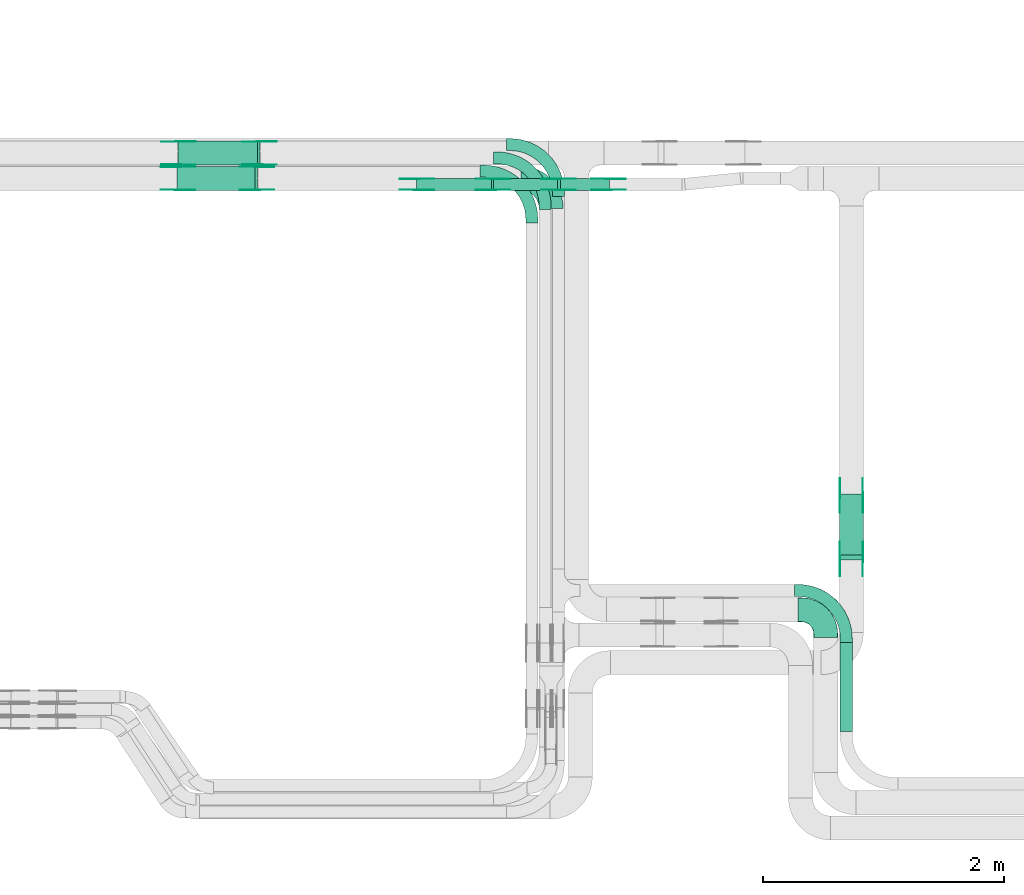
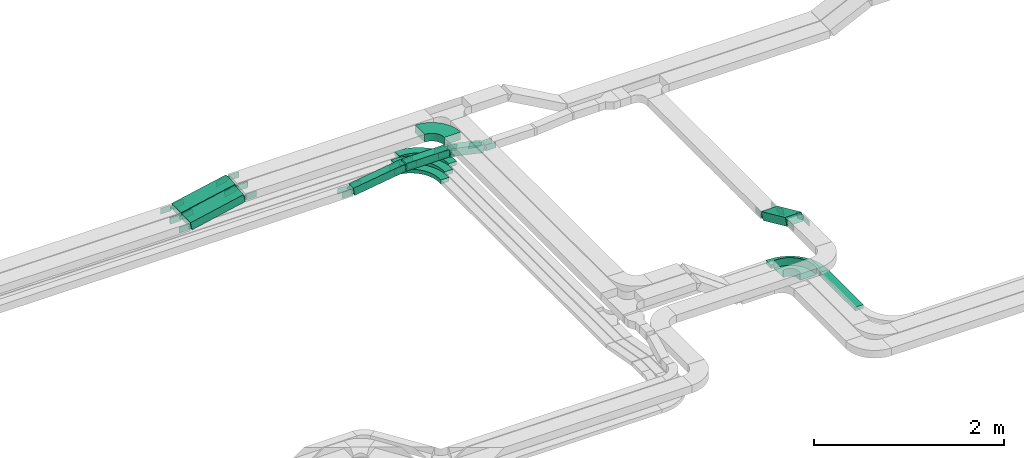
# One storey, part 12 of 25: 46 flow fittings, 7 flow segments.
"""IFC2X3 building model written with IfcOpenShell, lengths in millimetres."""

import ifcopenshell
import ifcopenshell.guid

model = None  # the IFC model being written
_history = None  # IfcOwnerHistory: only IFC2X3 demands one
_inside = {}  # id of a spatial element -> (the spatial element, [elements in it])
_under = {}  # id of a project, library or spatial element -> (it, [spatial elements below it])
_declared = {}  # id of a project -> (the project, [libraries it declares])
_typed = {}  # id of a type object -> (the type object, [elements of that type])
_made_of = {}  # id of a material, layer set ... -> (it, [elements and type objects made of it])


def new_model(schema):
    """Start an empty IFC model of exactly this schema.

    Asked for "IFC4X3", IfcOpenShell would pick the latest addendum, in which some entities
    have other attributes; the version numbers below select the first issue.
    IFC2X3 requires an IfcOwnerHistory on every rooted entity: one is made here for all.
    """
    global model, _history
    if schema == "IFC4X3":
        model = ifcopenshell.file(schema_version=(4, 3, 0, 0))
    else:
        model = ifcopenshell.file(schema=schema)
    _inside.clear()
    _under.clear()
    _declared.clear()
    _typed.clear()
    _made_of.clear()
    _history = None
    if model.schema == "IFC2X3":
        org = make("IfcOrganization", Name="unknown")
        user = make(
            "IfcPersonAndOrganization",
            ThePerson=make("IfcPerson", FamilyName="unknown"),
            TheOrganization=org,
        )
        app = make(
            "IfcApplication",
            ApplicationDeveloper=org,
            Version="unknown",
            ApplicationFullName="unknown",
            ApplicationIdentifier="unknown",
        )
        _history = make(
            "IfcOwnerHistory",
            OwningUser=user,
            OwningApplication=app,
            ChangeAction="ADDED",
            CreationDate=0,
        )
    return model


def make(cls, **values):
    """One entity of the class cls with the attributes given. An attribute that is None is left unset."""
    return model.create_entity(
        cls, **{name: value for name, value in values.items() if value is not None}
    )


def entity(cls, *values):
    """Any entity or typed value of the class cls, its attributes in the order of the schema. None: left unset."""
    e = model.create_entity(cls)
    for i, value in enumerate(values):
        if value is not None:
            e[i] = value
    return e


def rooted(cls, **values):
    """An entity with a GlobalId (a new one), such as an element, a storey or a relation."""
    return make(cls, GlobalId=ifcopenshell.guid.new(), OwnerHistory=_history, **values)


def si_unit(unit_type, name, prefix=None):
    """IfcSIUnit, for example si_unit("LENGTHUNIT", "METRE", prefix="MILLI")."""
    return make("IfcSIUnit", UnitType=unit_type, Prefix=prefix, Name=name)


def converted_unit(unit_type, name, factor, base, dimensions=None, offset=None):
    """IfcConversionBasedUnit, such as the inch: factor (a typed value) times the base unit."""
    return make(
        "IfcConversionBasedUnit"
        if offset is None
        else "IfcConversionBasedUnitWithOffset",
        ConversionOffset=offset,
        Dimensions=None
        if dimensions is None
        else entity("IfcDimensionalExponents", *dimensions),
        UnitType=unit_type,
        Name=name,
        ConversionFactor=make(
            "IfcMeasureWithUnit", ValueComponent=factor, UnitComponent=base
        ),
    )


def derived_unit(unit_type, elements):
    """IfcDerivedUnit: a product of units, each with its exponent."""
    return make(
        "IfcDerivedUnit",
        Elements=[
            make("IfcDerivedUnitElement", Unit=unit, Exponent=power)
            for unit, power in elements
        ],
        UnitType=unit_type,
    )


def assignment(units):
    """IfcUnitAssignment: the units of a project."""
    return None if units is None else make("IfcUnitAssignment", Units=units)


def point(xyz):
    """IfcCartesianPoint."""
    return None if xyz is None else make("IfcCartesianPoint", Coordinates=xyz)


def direction(xyz):
    """IfcDirection."""
    return None if xyz is None else make("IfcDirection", DirectionRatios=xyz)


def frame(location, z_axis=None, x_axis=None):
    """IfcAxis2Placement3D, a coordinate frame: its origin and axes. An axis left out is left unset."""
    return make(
        "IfcAxis2Placement3D",
        Location=point(location),
        Axis=direction(z_axis),
        RefDirection=direction(x_axis),
    )


def frame_2d(location, x_axis=None):
    """IfcAxis2Placement2D, a coordinate frame in the plane: its origin and x axis."""
    return make(
        "IfcAxis2Placement2D", Location=point(location), RefDirection=direction(x_axis)
    )


def origin():
    """The frame at (0, 0, 0) with its axes left unset."""
    return frame((0.0, 0.0, 0.0))


def origin_2d_with_axis():
    """The frame at (0, 0) in the plane with the x axis (1, 0) written out."""
    return frame_2d((0.0, 0.0), x_axis=(1.0, 0.0))


def place(relative_to, where):
    """IfcLocalPlacement: puts the frame where relative to a parent placement (None: the world)."""
    return make(
        "IfcLocalPlacement", PlacementRelTo=relative_to, RelativePlacement=where
    )


def context(
    kind, dimensions, precision=None, world=None, true_north=None, identifier=None
):
    """IfcGeometricRepresentationContext, for example the 3D "Model" context."""
    return make(
        "IfcGeometricRepresentationContext",
        ContextIdentifier=identifier,
        ContextType=kind,
        CoordinateSpaceDimension=dimensions,
        Precision=precision,
        WorldCoordinateSystem=world,
        TrueNorth=true_north,
    )


def subcontext(parent, identifier, kind, view, scale=None):
    """IfcGeometricRepresentationSubContext, for example "Body" below "Model"."""
    return make(
        "IfcGeometricRepresentationSubContext",
        ContextIdentifier=identifier,
        ContextType=kind,
        ParentContext=parent,
        TargetScale=scale,
        TargetView=view,
    )


def project(units=None, contexts=None):
    """IfcProject with its units and contexts."""
    return rooted(
        "IfcProject",
        Name="project",
        RepresentationContexts=contexts,
        UnitsInContext=assignment(units),
    )


def spatial(cls, under=None, at=None, **own):
    """A site, building, storey or space (cls), placed at a placement, below another one or the project."""
    s = rooted(cls, ObjectPlacement=at, **own)
    if under is not None:
        _under.setdefault(under.id(), (under, []))[1].append(s)
    return s


def polyline(points):
    """IfcPolyline through the points."""
    return make("IfcPolyline", Points=[point(p) for p in points])


def circle_curve(where, radius):
    """IfcCircle in the frame where."""
    return make("IfcCircle", Position=where, Radius=radius)


def parameter(value):
    """IfcParameterValue: where a trimmed curve begins or ends, as a parameter of its basis curve."""
    return model.create_entity("IfcParameterValue", value)


def trimmed(basis, trim1, trim2, sense, master):
    """IfcTrimmedCurve: the piece of a basis curve between two trims."""
    return make(
        "IfcTrimmedCurve",
        BasisCurve=basis,
        Trim1=trim1,
        Trim2=trim2,
        SenseAgreement=sense,
        MasterRepresentation=master,
    )


def segment(curve, same_sense, transition):
    """IfcCompositeCurveSegment."""
    return make(
        "IfcCompositeCurveSegment",
        Transition=transition,
        SameSense=same_sense,
        ParentCurve=curve,
    )


def composite_curve(segments, self_intersect=None):
    """IfcCompositeCurve: segments joined end to end."""
    return make("IfcCompositeCurve", Segments=segments, SelfIntersect=self_intersect)


def profile(cls, at=None, kind="AREA", **sizes):
    """A parametric profile (cls). Its sizes go by their IFC names, for example OverallWidth=200.0."""
    return make(cls, ProfileType=kind, Position=at, **sizes)


def rectangle(**sizes):
    """IfcRectangleProfileDef."""
    return profile("IfcRectangleProfileDef", **sizes)


def outline(outer, holes=None, kind="AREA"):
    """IfcArbitraryClosedProfileDef: a profile drawn as a closed curve; with holes, ...WithVoids."""
    if holes is None:
        return make("IfcArbitraryClosedProfileDef", ProfileType=kind, OuterCurve=outer)
    return make(
        "IfcArbitraryProfileDefWithVoids",
        ProfileType=kind,
        OuterCurve=outer,
        InnerCurves=holes,
    )


def extrude(swept, where, along, depth):
    """IfcExtrudedAreaSolid: the profile swept, set in the frame where, extruded along a direction by depth."""
    return make(
        "IfcExtrudedAreaSolid",
        SweptArea=swept,
        Position=where,
        ExtrudedDirection=direction(along),
        Depth=depth,
    )


def faces_of(points, faces, orient=None, outer=None):
    """IfcFace entities. A face is a list of loops; a loop is a list of indices into points, from 0.

    orient and outer hold one flag for each loop. By default every Orientation is true, the
    first loop of a face is its IfcFaceOuterBound and the others are IfcFaceBound.
    """
    made = []
    for i, loops in enumerate(faces):
        bounds = []
        for j, loop in enumerate(loops):
            is_outer = j == 0 if outer is None else outer[i][j]
            bounds.append(
                make(
                    "IfcFaceOuterBound" if is_outer else "IfcFaceBound",
                    Bound=make("IfcPolyLoop", Polygon=[points[k] for k in loop]),
                    Orientation=True if orient is None else orient[i][j],
                )
            )
        made.append(make("IfcFace", Bounds=bounds))
    return made


def faceted_brep(points, faces, orient=None, outer=None, voids=None):
    """IfcFacetedBrep: a solid bounded by flat faces; with voids (closed shells), ...WithVoids."""
    shared = [point(p) for p in points]
    hull = make("IfcClosedShell", CfsFaces=faces_of(shared, faces, orient, outer))
    if voids is None:
        return make("IfcFacetedBrep", Outer=hull)
    return make(
        "IfcFacetedBrepWithVoids",
        Outer=hull,
        Voids=[
            make(cls, CfsFaces=faces_of(shared, fs, o, b)) for cls, fs, o, b in voids
        ],
    )


def shape(context_of_items, identifier, shape_type, items):
    """IfcShapeRepresentation: the items that make up one representation, for example the "Body"."""
    return make(
        "IfcShapeRepresentation",
        ContextOfItems=context_of_items,
        RepresentationIdentifier=identifier,
        RepresentationType=shape_type,
        Items=items,
    )


def source(mapping_origin, context_of_items, identifier, shape_type, items):
    """IfcRepresentationMap: a shape defined once, which mapped items show again and again."""
    return make(
        "IfcRepresentationMap",
        MappingOrigin=mapping_origin,
        MappedRepresentation=shape(context_of_items, identifier, shape_type, items),
    )


def transform(
    local_origin,
    x_axis=None,
    y_axis=None,
    z_axis=None,
    scale=None,
    scale2=None,
    scale3=None,
    uniform=True,
):
    """IfcCartesianTransformationOperator3D, or its non-uniform kind. x_axis, y_axis, z_axis: its Axis1, 2, 3."""
    if uniform:
        return make(
            "IfcCartesianTransformationOperator3D",
            Axis1=direction(x_axis),
            Axis2=direction(y_axis),
            LocalOrigin=point(local_origin),
            Scale=scale,
            Axis3=direction(z_axis),
        )
    return make(
        "IfcCartesianTransformationOperator3DnonUniform",
        Axis1=direction(x_axis),
        Axis2=direction(y_axis),
        LocalOrigin=point(local_origin),
        Scale=scale,
        Axis3=direction(z_axis),
        Scale2=scale2,
        Scale3=scale3,
    )


def mapped(mapping_source, mapping_target):
    """IfcMappedItem: shows the shape of a source again, moved by a transform."""
    return make(
        "IfcMappedItem", MappingSource=mapping_source, MappingTarget=mapping_target
    )


def material(Name=None, Category=None):
    """IfcMaterial."""
    return make("IfcMaterial", Name=Name, Category=Category)


def made_of(thing, what):
    """Note that an element or type object is made of a material, layer set ...; save() writes the relation."""
    if what is not None:
        _made_of.setdefault(what.id(), (what, []))[1].append(thing)
    return thing


def type_object(cls, material=None, **own):
    """A type object (cls), such as IfcWallType, which elements share."""
    return made_of(rooted(cls, **own), material)


def type_shapes(of_type, sources):
    """Give a type object the sources (RepresentationMaps) that its elements show as mapped items."""
    of_type.RepresentationMaps = sources


def element(
    cls,
    number,
    at=None,
    inside=None,
    cuts=None,
    type_object=None,
    material=None,
    context=None,
    identifier="Body",
    shape_type=None,
    held_by="IfcProductDefinitionShape",
    body=None,
    shapes=None,
    **own,
):
    """One element of the class cls, such as IfcWall. Its Tag is "e" and its number.

    at: its placement. inside: the storey or other place that contains it. cuts: it is an
    opening in that element (IfcRelVoidsElement). A single representation is given by context,
    identifier, shape_type and body (its items); several are given by shapes. held_by: the class
    of the entity that holds the representations. save() writes the other relations.
    """
    e = rooted(cls, Tag="e%d" % number, ObjectPlacement=at, **own)
    if body is not None:
        shapes = [shape(context, identifier, shape_type, body)]
    if shapes is not None:
        e.Representation = make(held_by, Representations=shapes)
    if inside is not None:
        _inside.setdefault(inside.id(), (inside, []))[1].append(e)
    if cuts is not None:
        rooted(
            "IfcRelVoidsElement", RelatingBuildingElement=cuts, RelatedOpeningElement=e
        )
    if type_object is not None:
        _typed.setdefault(type_object.id(), (type_object, []))[1].append(e)
    return made_of(e, material)


def aggregate(whole, parts):
    """IfcRelAggregates: a whole, such as a stair, and the parts it consists of."""
    return rooted("IfcRelAggregates", RelatingObject=whole, RelatedObjects=parts)


def save(model, path):
    """Write the relations noted so far, then the file.

    IfcRelAggregates (storeys below a building ...), IfcRelContainedInSpatialStructure (elements
    in a storey), IfcRelDefinesByType, IfcRelAssociatesMaterial and IfcRelDeclares: one each for
    every whole, place, type object, material and project.
    """
    for whole, parts in _under.values():
        aggregate(whole, parts)
    for where, things in _inside.values():
        rooted(
            "IfcRelContainedInSpatialStructure",
            RelatedElements=things,
            RelatingStructure=where,
        )
    for kind, things in _typed.values():
        rooted("IfcRelDefinesByType", RelatedObjects=things, RelatingType=kind)
    for what, things in _made_of.values():
        rooted("IfcRelAssociatesMaterial", RelatedObjects=things, RelatingMaterial=what)
    for by, libraries in _declared.values():
        rooted("IfcRelDeclares", RelatingContext=by, RelatedDefinitions=libraries)
    model.write(path)


model = new_model("IFC2X3")

# Units and contexts
model_context = context("Model", 3, precision=0.01, world=origin(), true_north=direction((6.12303176911189e-17, 1.0)))
body_context = subcontext(model_context, "Body", "Model", "MODEL_VIEW")
ifc_project = project(units=[si_unit("LENGTHUNIT", "METRE", prefix="MILLI"), si_unit("AREAUNIT", "SQUARE_METRE"), si_unit("VOLUMEUNIT", "CUBIC_METRE"), converted_unit("PLANEANGLEUNIT", "DEGREE", entity("IfcRatioMeasure", 0.0174532925199433), si_unit("PLANEANGLEUNIT", "RADIAN"), dimensions=[0, 0, 0, 0, 0, 0, 0]), si_unit("MASSUNIT", "GRAM", prefix="KILO"), derived_unit("MASSDENSITYUNIT", [(si_unit("MASSUNIT", "GRAM", prefix="KILO"), 1), (si_unit("LENGTHUNIT", "METRE"), -3)]), derived_unit("MOMENTOFINERTIAUNIT", [(si_unit("LENGTHUNIT", "METRE"), 4)]), si_unit("TIMEUNIT", "SECOND"), si_unit("FREQUENCYUNIT", "HERTZ"), si_unit("THERMODYNAMICTEMPERATUREUNIT", "DEGREE_CELSIUS"), derived_unit("THERMALTRANSMITTANCEUNIT", [(si_unit("MASSUNIT", "GRAM", prefix="KILO"), 1), (si_unit("THERMODYNAMICTEMPERATUREUNIT", "KELVIN"), -1), (si_unit("TIMEUNIT", "SECOND"), -3)]), derived_unit("VOLUMETRICFLOWRATEUNIT", [(si_unit("LENGTHUNIT", "METRE"), 3), (si_unit("TIMEUNIT", "SECOND"), -1)]), derived_unit("MASSFLOWRATEUNIT", [(si_unit("MASSUNIT", "GRAM", prefix="KILO"), 1), (si_unit("TIMEUNIT", "SECOND"), -1)]), derived_unit("ROTATIONALFREQUENCYUNIT", [(si_unit("TIMEUNIT", "SECOND"), -1)]), si_unit("ELECTRICCURRENTUNIT", "AMPERE"), si_unit("ELECTRICVOLTAGEUNIT", "VOLT"), si_unit("POWERUNIT", "WATT"), si_unit("FORCEUNIT", "NEWTON", prefix="KILO"), si_unit("ILLUMINANCEUNIT", "LUX"), si_unit("LUMINOUSFLUXUNIT", "LUMEN"), si_unit("LUMINOUSINTENSITYUNIT", "CANDELA"), derived_unit("USERDEFINED", [(si_unit("MASSUNIT", "GRAM", prefix="KILO"), -1), (si_unit("LENGTHUNIT", "METRE"), -2), (si_unit("TIMEUNIT", "SECOND"), 3), (si_unit("LUMINOUSFLUXUNIT", "LUMEN"), 1)]), derived_unit("LINEARVELOCITYUNIT", [(si_unit("LENGTHUNIT", "METRE"), 1), (si_unit("TIMEUNIT", "SECOND"), -1)]), si_unit("PRESSUREUNIT", "PASCAL"), derived_unit("USERDEFINED", [(si_unit("LENGTHUNIT", "METRE"), -2), (si_unit("MASSUNIT", "GRAM", prefix="KILO"), 1), (si_unit("TIMEUNIT", "SECOND"), -2)]), derived_unit("LINEARFORCEUNIT", [(si_unit("MASSUNIT", "GRAM", prefix="KILO"), 1), (si_unit("LENGTHUNIT", "METRE"), 1), (si_unit("TIMEUNIT", "SECOND"), -2), (si_unit("LENGTHUNIT", "METRE"), -1)]), derived_unit("PLANARFORCEUNIT", [(si_unit("MASSUNIT", "GRAM", prefix="KILO"), 1), (si_unit("LENGTHUNIT", "METRE"), 1), (si_unit("TIMEUNIT", "SECOND"), -2), (si_unit("LENGTHUNIT", "METRE"), -2)])], contexts=[model_context])

# Site, building, storey
site_placement = place(None, frame((0.0, -0.00077364408347762, 0.0)))
site = spatial("IfcSite", under=ifc_project, at=site_placement, CompositionType="ELEMENT")
building_placement = place(site_placement, origin())
building = spatial("IfcBuilding", under=site, at=building_placement, CompositionType="ELEMENT")
storey_placement = place(building_placement, frame((0.0, 0.0, 24000.0)))
storey = spatial("IfcBuildingStorey", under=building, at=storey_placement, CompositionType="ELEMENT", Elevation=24000.0)

# Flow segments
cable_carrier_segment_type = type_object("IfcCableCarrierSegmentType", PredefinedType="CABLETRAYSEGMENT")
flow_segment_1_placement = place(storey_placement, frame((35443.0827924389, 9874.94253623869, 2660.0)))
element("IfcFlowSegment", 1, at=flow_segment_1_placement, inside=storey, type_object=cable_carrier_segment_type, context=body_context, shape_type="SweptSolid", body=[
    extrude(rectangle(XDim=741.957859858951, YDim=100.000000000003, at=origin_2d_with_axis()), frame((50.0, 370.978929929476, 0.0), z_axis=(0.0, 0.0, 1.0), x_axis=(0.0, -1.0, 0.0)), (0.0, 0.0, 1.0), 49.9999999999973),
])
flow_segment_2_placement = place(storey_placement, frame((29938.2616836239, 14367.8235638228, 2902.46442439066)))
element("IfcFlowSegment", 2, at=flow_segment_2_placement, inside=storey, type_object=cable_carrier_segment_type, context=body_context, shape_type="SweptSolid", body=[
    extrude(rectangle(XDim=100.000000000002, YDim=199.999999999998, at=frame_2d((0.0, 0.0), x_axis=(0.0, 1.0))), frame((10.3606064094728, 100.0, 48.9148017968845), z_axis=(0.978296035937588, 0.0, 0.207212128189452), x_axis=(0.0, 1.0, 0.0)), (0.0, 0.0, 1.0), 662.323913296523),
])
flow_segment_3_placement = place(storey_placement, frame((29945.3217316781, 14577.8235638228, 2902.37682935703)))
element("IfcFlowSegment", 3, at=flow_segment_3_placement, inside=storey, type_object=cable_carrier_segment_type, context=body_context, shape_type="SweptSolid", body=[
    extrude(rectangle(XDim=99.9999999999976, YDim=199.999999999998, at=frame_2d((0.0, 0.0), x_axis=(0.0, 1.0))), frame((10.1686392190644, 100.0, 48.955068955446), z_axis=(0.979101379108944, 0.0, 0.203372784381206), x_axis=(0.0, 1.0, 0.0)), (0.0, 0.0, 1.0), 675.292929646166),
])
flow_segment_4_placement = place(storey_placement, frame((32566.6569789908, 14367.8235638228, 2743.47367481726)))
element("IfcFlowSegment", 4, at=flow_segment_4_placement, inside=storey, type_object=cable_carrier_segment_type, context=body_context, shape_type="SweptSolid", body=[
    extrude(rectangle(XDim=528.117388360168, YDim=99.9999999999989, at=frame_2d((-2.1600499167107e-12, 1.08357767203415e-12), x_axis=(1.0, 0.0))), frame((264.058694180091, 50.0, 0.0)), (0.0, 0.0, 1.0), 100.000000000003),
])
flow_segment_5_placement = place(storey_placement, frame((31923.8620126346, 14367.8235638228, 2651.25271057159)))
element("IfcFlowSegment", 5, at=flow_segment_5_placement, inside=storey, type_object=cable_carrier_segment_type, context=body_context, shape_type="SweptSolid", body=[
    extrude(rectangle(XDim=99.9999999999993, YDim=99.9999999999989, at=frame_2d((0.0, 2.16715534406831e-12), x_axis=(1.0, 0.0))), frame((7.27643817058358, 50.0, 49.4677010538147), z_axis=(0.9893540210763, 0.0, 0.145528763411759), x_axis=(-0.145528763411759, 0.0, 0.9893540210763)), (0.0, 0.0, 1.0), 632.403171778338),
])
flow_segment_6_placement = place(storey_placement, frame((33097.6188980036, 14367.8235638228, 2652.69744610507)))
element("IfcFlowSegment", 6, at=flow_segment_6_placement, inside=storey, type_object=cable_carrier_segment_type, context=body_context, shape_type="SweptSolid", body=[
    extrude(rectangle(XDim=99.9999999999984, YDim=99.9999999999989, at=frame_2d((0.0, 4.68958205601666e-13), x_axis=(0.0, 1.0))), frame((10.8547522753288, 50.0, 139.271259078084), z_axis=(0.976150470581497, 0.0, -0.217095045506624), x_axis=(0.0, 1.0, 0.0)), (0.0, 0.0, 1.0), 416.70105984177),
])
flow_segment_7_placement = place(storey_placement, frame((35435.6156945545, 11298.7278543462, 2659.6732728103)))
element("IfcFlowSegment", 7, at=flow_segment_7_placement, inside=storey, type_object=cable_carrier_segment_type, context=body_context, shape_type="SweptSolid", body=[
    extrude(rectangle(XDim=100.000000000003, YDim=556.494140571385, at=frame_2d((8.5265128291212e-14, 2.41939801526314e-12), x_axis=(0.0, 1.0))), frame((0.0, 274.095709476673, 160.326727189748), z_axis=(1.0, 0.0, 0.0), x_axis=(0.0, -0.910954180221993, 0.412507553307909)), (0.0, 0.0, 1.0), 199.999999999998),
])

# Flow fittings
ifc_material_1 = material(Name="G")
cable_carrier_fitting_type_1 = type_object("IfcCableCarrierFittingType", PredefinedType="NOTDEFINED", material=ifc_material_1)
shared_shape_1 = source(origin(), body_context, "Body", "SweptSolid", [
    extrude(outline(composite_curve([segment(trimmed(circle_curve(frame_2d((-41.4651162790697, 0.0), x_axis=(1.0, 0.0)), 25.0), [parameter(90.0000000000007)], [parameter(270.0)], True, "PARAMETER"), True, "CONTINUOUS"), segment(polyline([(-41.4651162790697, -25.0), (-29.9651162790697, -25.0)]), True, "CONTINUOUS"), segment(polyline([(-29.9651162790697, -25.0), (-28.1046511627907, -38.5)]), True, "CONTINUOUS"), segment(polyline([(-28.1046511627907, -38.5), (99.5348837209303, -38.5)]), True, "CONTINUOUS"), segment(polyline([(99.5348837209303, -38.5), (99.5348837209303, 38.5)]), True, "CONTINUOUS"), segment(polyline([(99.5348837209303, 38.5), (-28.1046511627907, 38.5)]), True, "CONTINUOUS"), segment(polyline([(-28.1046511627907, 38.5), (-29.9651162790697, 25.0)]), True, "CONTINUOUS"), segment(polyline([(-29.9651162790697, 25.0), (-41.46511627907, 25.0)]), True, "CONTINUOUS")], self_intersect=False)), frame((41.4651162790697, 0.0, 0.0), z_axis=(0.0, 0.0, -1.0), x_axis=(1.0, 0.0, 0.0)), (0.0, 0.0, -1.0), 2.0),
])
type_shapes(cable_carrier_fitting_type_1, [shared_shape_1])
for number, where, z_axis, x_axis in (
    (8, (29942.1106465126, 14372.3635638126, 2950.0), (0.0, -1.0, 0.0), (0.978296035937579, 0.0, 0.207212128189496)),
    (9, (30603.0827924388, 14372.3635638126, 3090.0), (0.0, -1.0, 0.0), (-0.978296035937579, 0.0, -0.207212128189496)),
    (10, (29949.0781880745, 14582.3635638127, 2950.0), (0.0, -1.0, 0.0), (0.979101379108938, 0.0, 0.203372784381233)),
    (11, (32561.706674952, 14372.3635638126, 2793.47367481727), (0.0, -1.0, 0.0), (-0.989354021076303, 0.0, -0.145528763411741)),
    (12, (31926.2408475988, 14372.3635638126, 2700.0), (0.0, -1.0, 0.0), (0.989354021076303, 0.0, 0.145528763411741)),
    (13, (33101.706674952, 14463.2835638329, 2793.47367481728), (0.0, 1.0, 0.0), (0.976150470581499, 0.0, -0.217095045506614)),
    (14, (33522.0035612623, 14463.2835638329, 2700.0), (0.0, 1.0, 0.0), (-0.976150470581499, 0.0, 0.217095045506614)),
    (15, (30623.0827924389, 14773.283563833, 3090.0), (0.0, 1.0, 0.0), (1.0, 0.0, 0.0)),
    (16, (35440.1556945444, 11837.8235638229, 2700.0), (-1.0, 0.0, 0.0), (0.0, -0.910954180221981, 0.412507553307936)),
    (17, (35440.1556945444, 11307.8235638228, 2940.0), (-1.0, 0.0, 0.0), (0.0, 0.910954180221981, -0.412507553307936)),
):
    element("IfcFlowFitting", number, at=place(storey_placement, frame(where, z_axis=z_axis, x_axis=x_axis)), inside=storey, type_object=cable_carrier_fitting_type_1, material=ifc_material_1, context=body_context, shape_type="MappedRepresentation", body=[
        mapped(shared_shape_1, transform((0.0, 0.0, 0.0), scale=1.0)),
    ])
cable_carrier_fitting_type_2 = type_object("IfcCableCarrierFittingType", PredefinedType="NOTDEFINED", material=ifc_material_1)
shared_shape_2 = source(origin(), body_context, "Body", "SweptSolid", [
    extrude(outline(composite_curve([segment(trimmed(circle_curve(frame_2d((-41.4651162790697, 0.0), x_axis=(1.0, 0.0)), 25.0), [parameter(90.0000000000007)], [parameter(270.0)], True, "PARAMETER"), True, "CONTINUOUS"), segment(polyline([(-41.4651162790697, -25.0), (-29.9651162790697, -25.0)]), True, "CONTINUOUS"), segment(polyline([(-29.9651162790697, -25.0), (-28.1046511627907, -38.5)]), True, "CONTINUOUS"), segment(polyline([(-28.1046511627907, -38.5), (99.5348837209303, -38.5)]), True, "CONTINUOUS"), segment(polyline([(99.5348837209303, -38.5), (99.5348837209303, 38.5)]), True, "CONTINUOUS"), segment(polyline([(99.5348837209303, 38.5), (-28.1046511627907, 38.5)]), True, "CONTINUOUS"), segment(polyline([(-28.1046511627907, 38.5), (-29.9651162790697, 25.0)]), True, "CONTINUOUS"), segment(polyline([(-29.9651162790697, 25.0), (-41.46511627907, 25.0)]), True, "CONTINUOUS")], self_intersect=False)), frame((41.4651162790697, 0.0, 0.0)), (0.0, 0.0, 1.0), 2.0),
])
type_shapes(cable_carrier_fitting_type_2, [shared_shape_2])
for number, where, z_axis, x_axis in (
    (18, (29942.1106465126, 14563.283563833, 2950.0), (0.0, 1.0, 0.0), (0.978296035937579, 0.0, 0.207212128189496)),
    (19, (30603.0827924388, 14563.283563833, 3090.0), (0.0, 1.0, 0.0), (-0.978296035937579, 0.0, -0.207212128189496)),
    (20, (29949.0781880745, 14773.283563833, 2950.0), (0.0, 1.0, 0.0), (0.979101379108938, 0.0, 0.203372784381233)),
    (21, (32561.706674952, 14463.2835638329, 2793.47367481727), (0.0, 1.0, 0.0), (-0.989354021076303, 0.0, -0.145528763411741)),
    (22, (31926.2408475988, 14463.2835638329, 2700.0), (0.0, 1.0, 0.0), (0.989354021076303, 0.0, 0.145528763411741)),
    (23, (33101.706674952, 14372.3635638126, 2793.47367481728), (0.0, -1.0, 0.0), (0.976150470581499, 0.0, -0.217095045506614)),
    (24, (33522.0035612623, 14372.3635638126, 2700.0), (0.0, -1.0, 0.0), (-0.976150470581499, 0.0, 0.217095045506614)),
    (25, (30623.0827924389, 14582.3635638127, 3090.0), (0.0, -1.0, 0.0), (1.0, 0.0, 0.0)),
    (26, (35631.0756945647, 11837.8235638229, 2700.0), (1.0, 0.0, 0.0), (0.0, -0.910954180221981, 0.412507553307936)),
    (27, (35631.0756945647, 11307.8235638228, 2940.0), (1.0, 0.0, 0.0), (0.0, 0.910954180221981, -0.412507553307936)),
):
    element("IfcFlowFitting", number, at=place(storey_placement, frame(where, z_axis=z_axis, x_axis=x_axis)), inside=storey, type_object=cable_carrier_fitting_type_2, material=ifc_material_1, context=body_context, shape_type="MappedRepresentation", body=[
        mapped(shared_shape_2, transform((0.0, 0.0, 0.0), scale=1.0)),
    ])
cable_carrier_fitting_type_3 = type_object("IfcCableCarrierFittingType", PredefinedType="NOTDEFINED", material=ifc_material_1)
shared_shape_3 = source(origin(), body_context, "Body", "SweptSolid", [
    extrude(outline(composite_curve([segment(trimmed(circle_curve(frame_2d((-41.4651162790697, 0.0), x_axis=(1.0, 0.0)), 25.0), [parameter(90.0000000000007)], [parameter(270.0)], True, "PARAMETER"), True, "CONTINUOUS"), segment(polyline([(-41.4651162790697, -25.0), (-29.9651162790697, -25.0)]), True, "CONTINUOUS"), segment(polyline([(-29.9651162790697, -25.0), (-28.1046511627907, -38.5)]), True, "CONTINUOUS"), segment(polyline([(-28.1046511627907, -38.5), (99.5348837209303, -38.5)]), True, "CONTINUOUS"), segment(polyline([(99.5348837209303, -38.5), (99.5348837209303, 38.5)]), True, "CONTINUOUS"), segment(polyline([(99.5348837209303, 38.5), (-28.1046511627907, 38.5)]), True, "CONTINUOUS"), segment(polyline([(-28.1046511627907, 38.5), (-29.9651162790697, 25.0)]), True, "CONTINUOUS"), segment(polyline([(-29.9651162790697, 25.0), (-41.46511627907, 25.0)]), True, "CONTINUOUS")], self_intersect=False)), frame((41.4651162790697, 0.0, 0.0), z_axis=(0.0, 0.0, -1.0), x_axis=(1.0, 0.0, 0.0)), (0.0, 0.0, -1.0), 2.0),
])
type_shapes(cable_carrier_fitting_type_3, [shared_shape_3])
for number, where, z_axis, x_axis in (
    (28, (29942.1106465126, 14561.283563833, 2950.0), (0.0, 1.0, 0.0), (-1.0, 0.0, 0.0)),
    (29, (30603.0827924388, 14561.283563833, 3090.0), (0.0, 1.0, 0.0), (1.0, 0.0, 0.0)),
    (30, (29949.0781880745, 14771.283563833, 2950.0), (0.0, 1.0, 0.0), (-1.0, 0.0, 0.0)),
    (31, (32561.7066749519, 14461.2835638329, 2793.47367481727), (0.0, 1.0, 0.0), (1.0, 0.0, 0.0)),
    (32, (31926.2408475988, 14461.2835638329, 2700.0), (0.0, 1.0, 0.0), (-1.0, 0.0, 0.0)),
    (33, (33101.706674952, 14374.3635638126, 2793.47367481728), (0.0, -1.0, 0.0), (-1.0, 0.0, 0.0)),
    (34, (33522.0035612622, 14374.3635638126, 2700.0), (0.0, -1.0, 0.0), (1.0, 0.0, 0.0)),
    (35, (30623.0827924389, 14584.3635638127, 3090.0), (0.0, -1.0, 0.0), (-0.979101379108942, 0.0, -0.203372784381214)),
    (36, (35629.0756945647, 11837.8235638229, 2700.0), (1.0, 0.0, 0.0), (0.0, 1.0, 0.0)),
    (37, (35629.0756945647, 11307.8235638228, 2940.0), (1.0, 0.0, 0.0), (0.0, -1.0, 0.0)),
):
    element("IfcFlowFitting", number, at=place(storey_placement, frame(where, z_axis=z_axis, x_axis=x_axis)), inside=storey, type_object=cable_carrier_fitting_type_3, material=ifc_material_1, context=body_context, shape_type="MappedRepresentation", body=[
        mapped(shared_shape_3, transform((0.0, 0.0, 0.0), scale=1.0)),
    ])
cable_carrier_fitting_type_4 = type_object("IfcCableCarrierFittingType", PredefinedType="NOTDEFINED", material=ifc_material_1)
shared_shape_4 = source(origin(), body_context, "Body", "SweptSolid", [
    extrude(outline(composite_curve([segment(trimmed(circle_curve(frame_2d((-41.4651162790697, 0.0), x_axis=(1.0, 0.0)), 25.0), [parameter(90.0000000000007)], [parameter(270.0)], True, "PARAMETER"), True, "CONTINUOUS"), segment(polyline([(-41.4651162790697, -25.0), (-29.9651162790697, -25.0)]), True, "CONTINUOUS"), segment(polyline([(-29.9651162790697, -25.0), (-28.1046511627907, -38.5)]), True, "CONTINUOUS"), segment(polyline([(-28.1046511627907, -38.5), (99.5348837209303, -38.5)]), True, "CONTINUOUS"), segment(polyline([(99.5348837209303, -38.5), (99.5348837209303, 38.5)]), True, "CONTINUOUS"), segment(polyline([(99.5348837209303, 38.5), (-28.1046511627907, 38.5)]), True, "CONTINUOUS"), segment(polyline([(-28.1046511627907, 38.5), (-29.9651162790697, 25.0)]), True, "CONTINUOUS"), segment(polyline([(-29.9651162790697, 25.0), (-41.46511627907, 25.0)]), True, "CONTINUOUS")], self_intersect=False)), frame((41.4651162790697, 0.0, 0.0)), (0.0, 0.0, 1.0), 2.0),
])
type_shapes(cable_carrier_fitting_type_4, [shared_shape_4])
for number, where, z_axis, x_axis in (
    (38, (29942.1106465126, 14374.3635638127, 2950.0), (0.0, -1.0, 0.0), (-1.0, 0.0, 0.0)),
    (39, (30603.0827924388, 14374.3635638127, 3090.0), (0.0, -1.0, 0.0), (1.0, 0.0, 0.0)),
    (40, (29949.0781880745, 14584.3635638127, 2950.0), (0.0, -1.0, 0.0), (-1.0, 0.0, 0.0)),
    (41, (32561.7066749519, 14374.3635638126, 2793.47367481726), (0.0, -1.0, 0.0), (1.0, 0.0, 0.0)),
    (42, (31926.2408475988, 14374.3635638126, 2700.0), (0.0, -1.0, 0.0), (-1.0, 0.0, 0.0)),
    (43, (33101.706674952, 14461.2835638329, 2793.47367481727), (0.0, 1.0, 0.0), (-1.0, 0.0, 0.0)),
    (44, (33522.0035612622, 14461.2835638329, 2700.0), (0.0, 1.0, 0.0), (1.0, 0.0, 0.0)),
    (45, (30623.0827924389, 14771.283563833, 3090.0), (0.0, 1.0, 0.0), (-0.979101379108942, 0.0, -0.203372784381214)),
    (46, (35442.1556945444, 11837.8235638229, 2700.0), (-1.0, 0.0, 0.0), (0.0, 1.0, 0.0)),
    (47, (35442.1556945444, 11307.8235638228, 2940.0), (-1.0, 0.0, 0.0), (0.0, -1.0, 0.0)),
):
    element("IfcFlowFitting", number, at=place(storey_placement, frame(where, z_axis=z_axis, x_axis=x_axis)), inside=storey, type_object=cable_carrier_fitting_type_4, material=ifc_material_1, context=body_context, shape_type="MappedRepresentation", body=[
        mapped(shared_shape_4, transform((0.0, 0.0, 0.0), scale=1.0)),
    ])
ifc_material_2 = material()
cable_carrier_fitting_type_5 = type_object("IfcCableCarrierFittingType", Name="470_DKC_S5_Variable Angle Elbow 0-45:-", PredefinedType="NOTDEFINED", material=ifc_material_2)
shared_shape_5 = source(origin(), body_context, "Body", "SweptSolid", [
    extrude(outline(composite_curve([segment(polyline([(-125.750000000001, -225.25), (-124.749999999999, -225.25)]), True, "CONTINUOUS"), segment(trimmed(circle_curve(frame_2d((-124.75, 124.75), x_axis=(0.0, -1.0)), 350.0), [parameter(0.0)], [parameter(90.0000000000001)], True, "PARAMETER"), True, "CONTINUOUS"), segment(polyline([(225.25, 124.75), (225.25, 125.749999999999)]), True, "CONTINUOUS"), segment(polyline([(225.25, 125.749999999999), (25.25, 125.750000000001)]), True, "CONTINUOUS"), segment(polyline([(25.25, 125.750000000001), (25.25, 124.75)]), True, "CONTINUOUS"), segment(trimmed(circle_curve(frame_2d((-124.75, 124.75), x_axis=(0.0, -1.0)), 150.0), [parameter(0.0)], [parameter(90.0000000000001)], True, "PARAMETER"), False, "CONTINUOUS"), segment(polyline([(-124.749999999999, -25.2500000000003), (-125.750000000001, -25.2500000000003)]), True, "CONTINUOUS"), segment(polyline([(-125.750000000001, -25.2500000000003), (-125.750000000001, -225.25)]), True, "CONTINUOUS")], self_intersect=False)), frame((-125.249999999991, 125.249999999992, -50.0)), (0.0, 0.0, 1.0), 100.0),
])
type_shapes(cable_carrier_fitting_type_5, [shared_shape_5])
flow_fitting_1_placement = place(storey_placement, frame((33043.0827924388, 14467.8235638228, 3090.0), z_axis=(0.0, 0.0, 1.0), x_axis=(0.0, 1.0, 0.0)))
element("IfcFlowFitting", 48, at=flow_fitting_1_placement, inside=storey, type_object=cable_carrier_fitting_type_5, material=ifc_material_2, Name="470_DKC_S5_Variable Angle Elbow 0-45:-", ObjectType="470_DKC_S5_Variable Angle Elbow 0-45:-", context=body_context, shape_type="MappedRepresentation", body=[
    mapped(shared_shape_5, transform((0.0, 0.0, 0.0), scale=1.0)),
])
cable_carrier_fitting_type_6 = type_object("IfcCableCarrierFittingType", Name="470_DKC_S5_CPO 45 horizontal angle:-", PredefinedType="NOTDEFINED", material=ifc_material_2)
shared_shape_6 = source(origin(), body_context, "Body", "Brep", [
    faceted_brep([(-230.0, -99.2000000000082, -49.2000000000019), (-230.0, 99.1999999999917, -49.2000000000019), (-230.0, 99.1999999999917, 50.0), (-230.0, 100.0, 50.0), (-230.0, 100.0, -50.0), (-230.0, -100.0, -50.0), (-230.0, -100.0, 50.0), (-230.0, -99.2000000000082, 50.0), (-200.0, -100.0, -50.0), (-200.0, -100.0, 50.0), (-141.472903395153, -94.2355841209775, 50.0), (-85.1949702904642, -77.1638597533945, 50.0), (-33.3289300941106, -49.4408836907721, 50.0), (12.132034355973, -12.1320343559729, 50.0), (49.4408836907724, 33.3289300941106, 50.0), (77.1638597533949, 85.1949702904643, 50.0), (94.2355841209781, 141.472903395153, 50.0), (100.0, 200.0, 50.0), (100.0, 230.0, 50.0), (99.2000000000087, 230.0, 50.0), (99.2000000000089, 200.0, 50.0), (93.4509558966552, 141.628975652766, 50.0), (76.4247561273856, 85.5011170363564, 50.0), (48.7757080009301, 33.7733862805264, 50.0), (11.5663489310236, -11.5663489310235, 50.0), (-33.7733862805263, -48.7757080009299, 50.0), (-85.5011170363564, -76.4247561273853, 50.0), (-141.628975652766, -93.4509558966548, 50.0), (-200.0, -99.2000000000082, 50.0), (-200.0, 99.1999999999917, 50.0), (-168.851086966996, 104.13350315744, 50.0), (-140.75124656891, 118.451086966997, 50.0), (-118.451086966997, 140.75124656891, 50.0), (-104.13350315744, 168.851086966997, 50.0), (-99.1999999999912, 200.0, 50.0), (-99.1999999999912, 230.0, 50.0), (-100.0, 230.0, 50.0), (-100.0, 200.0, 50.0), (-104.894348370476, 169.098300562497, 50.0), (-119.098300562496, 141.221474770744, 50.0), (-141.221474770744, 119.098300562497, 50.0), (-169.098300562496, 104.894348370476, 50.0), (-200.0, 100.0, 50.0), (-200.0, -99.2000000000082, -49.2000000000019), (-141.628975652766, -93.4509558966548, -49.2000000000019), (-85.5011170363564, -76.4247561273853, -49.2000000000019), (-33.7733862805263, -48.7757080009299, -49.2000000000019), (11.5663489310236, -11.5663489310235, -49.2000000000019), (48.7757080009301, 33.7733862805264, -49.2000000000019), (76.4247561273856, 85.5011170363564, -49.2000000000019), (93.4509558966552, 141.628975652766, -49.2000000000019), (99.2000000000087, 200.0, -49.2000000000019), (99.2000000000087, 230.0, -49.2000000000019), (-99.1999999999912, 230.0, -49.2000000000019), (-99.1999999999912, 200.0, -49.2000000000019), (-104.13350315744, 168.851086966997, -49.2000000000019), (-118.451086966997, 140.75124656891, -49.2000000000019), (-140.75124656891, 118.451086966997, -49.2000000000019), (-168.851086966996, 104.13350315744, -49.2000000000019), (-200.0, 99.1999999999917, -49.2000000000019), (-200.0, 100.0, -50.0), (-141.472903395153, -94.2355841209775, -50.0), (-169.098300562496, 104.894348370476, -50.0), (-141.221474770744, 119.098300562497, -50.0), (-119.098300562496, 141.221474770744, -50.0), (-104.894348370476, 169.098300562497, -50.0), (-100.0, 200.0, -50.0), (-100.0, 230.0, -50.0), (100.0, 230.0, -50.0), (100.0, 200.0, -50.0), (94.2355841209781, 141.472903395153, -50.0), (77.1638597533949, 85.1949702904643, -50.0), (49.4408836907724, 33.3289300941106, -50.0), (12.132034355973, -12.1320343559729, -50.0), (-33.3289300941106, -49.4408836907721, -50.0), (-85.1949702904642, -77.1638597533945, -50.0)], [[[0, 1, 2, 3, 4, 5, 6, 7]], [[6, 5, 8, 9]], [[7, 6, 9, 10, 11, 12, 13, 14, 15, 16, 17, 18, 19, 20, 21, 22, 23, 24, 25, 26, 27, 28]], [[3, 2, 29, 30, 31, 32, 33, 34, 35, 36, 37, 38, 39, 40, 41, 42]], [[0, 7, 28, 43]], [[1, 0, 43, 44, 45, 46, 47, 48, 49, 50, 51, 52, 53, 54, 55, 56, 57, 58, 59]], [[2, 1, 59, 29]], [[4, 3, 42, 60]], [[61, 8, 5, 4, 60, 62, 63, 64, 65, 66, 67, 68, 69, 70, 71, 72, 73, 74, 75]], [[10, 9, 8, 61]], [[61, 75, 11, 10]], [[74, 12, 11, 75]], [[73, 13, 12, 74]], [[14, 72, 71, 15]], [[15, 71, 70, 16]], [[16, 70, 69, 17]], [[73, 72, 14, 13]], [[44, 43, 28, 27]], [[26, 45, 44, 27]], [[45, 26, 25, 46]], [[25, 24, 47, 46]], [[49, 48, 23, 22]], [[50, 49, 22, 21]], [[51, 50, 21, 20]], [[24, 23, 48, 47]], [[58, 57, 31, 30]], [[59, 58, 30, 29]], [[57, 56, 32, 31]], [[32, 56, 55, 33]], [[33, 55, 54, 34]], [[41, 40, 63, 62]], [[41, 62, 60, 42]], [[40, 39, 64, 63]], [[65, 64, 39, 38]], [[66, 65, 38, 37]], [[67, 36, 35, 53, 52, 19, 18, 68]], [[17, 69, 68, 18]], [[51, 20, 19, 52]], [[34, 54, 53, 35]], [[66, 37, 36, 67]]]),
])
type_shapes(cable_carrier_fitting_type_6, [shared_shape_6])
flow_fitting_2_placement = place(storey_placement, frame((35323.0827924389, 10886.9003960975, 2710.0), z_axis=(0.0, 0.0, 1.0), x_axis=(0.0, 1.0, 0.0)))
element("IfcFlowFitting", 49, at=flow_fitting_2_placement, inside=storey, type_object=cable_carrier_fitting_type_6, material=ifc_material_2, Name="470_DKC_S5_45 horizontal angle", ObjectType="470_DKC_S5_CPO 45 horizontal angle:-", context=body_context, shape_type="MappedRepresentation", body=[
    mapped(shared_shape_6, transform((0.0, 0.0, 0.0), scale=1.0)),
])
cable_carrier_fitting_type_7 = type_object("IfcCableCarrierFittingType", Name="470_DKC_S5_CPO 45 horizontal angle:-", PredefinedType="NOTDEFINED", material=ifc_material_2)
shared_shape_7 = source(origin(), body_context, "Body", "SweptSolid", [
    extrude(outline(composite_curve([segment(polyline([(-222.5, -257.5), (-192.5, -257.5)]), True, "CONTINUOUS"), segment(trimmed(circle_curve(frame_2d((-192.5, 192.5), x_axis=(0.0, -1.0)), 450.0), [parameter(0.0)], [parameter(90.0)], True, "PARAMETER"), True, "CONTINUOUS"), segment(polyline([(257.5, 192.5), (257.5, 222.5)]), True, "CONTINUOUS"), segment(polyline([(257.5, 222.5), (157.5, 222.5)]), True, "CONTINUOUS"), segment(polyline([(157.5, 222.5), (157.5, 192.5)]), True, "CONTINUOUS"), segment(trimmed(circle_curve(frame_2d((-192.5, 192.5), x_axis=(0.0, -1.0)), 350.0), [parameter(0.0)], [parameter(90.0)], True, "PARAMETER"), False, "CONTINUOUS"), segment(polyline([(-192.5, -157.5), (-222.5, -157.5)]), True, "CONTINUOUS"), segment(polyline([(-222.5, -157.5), (-222.5, -257.5)]), True, "CONTINUOUS")], self_intersect=False)), frame((-207.499999999991, 207.499999999992, -25.0)), (0.0, 0.0, 1.0), 50.0000000000002),
])
type_shapes(cable_carrier_fitting_type_7, [shared_shape_7])
for number, where, z_axis, x_axis, name in (
    (50, (32883.0827924389, 14527.8235638227, 2675.0), (0.0, 0.0, 1.0), (0.0, 1.0, 0.0), "470_DKC_S5_45 horizontal angle"),
    (51, (32993.0827924389, 14637.8235638227, 2675.0), (0.0, 0.0, 1.0), (0.0, 1.0, 0.0), "470_DKC_S5_45 horizontal angle"),
    (52, (33103.0827924389, 14747.8235638227, 2675.0), (0.0, 0.0, 1.0), (0.0, 1.0, 0.0), "470_DKC_S5_45 horizontal angle"),
    (53, (35493.0827924389, 11046.9003960976, 2685.0), (-0.00450630910080412, 0.0, 0.999989846537598), (0.0, 1.0, 0.0), "470_DKC_S5_45 horizontal angle"),
):
    element("IfcFlowFitting", number, at=place(storey_placement, frame(where, z_axis=z_axis, x_axis=x_axis)), inside=storey, type_object=cable_carrier_fitting_type_7, material=ifc_material_2, Name=name, ObjectType="470_DKC_S5_CPO 45 horizontal angle:-", context=body_context, shape_type="MappedRepresentation", body=[
        mapped(shared_shape_7, transform((0.0, 0.0, 0.0), scale=1.0)),
    ])

save(model, "model.ifc")
